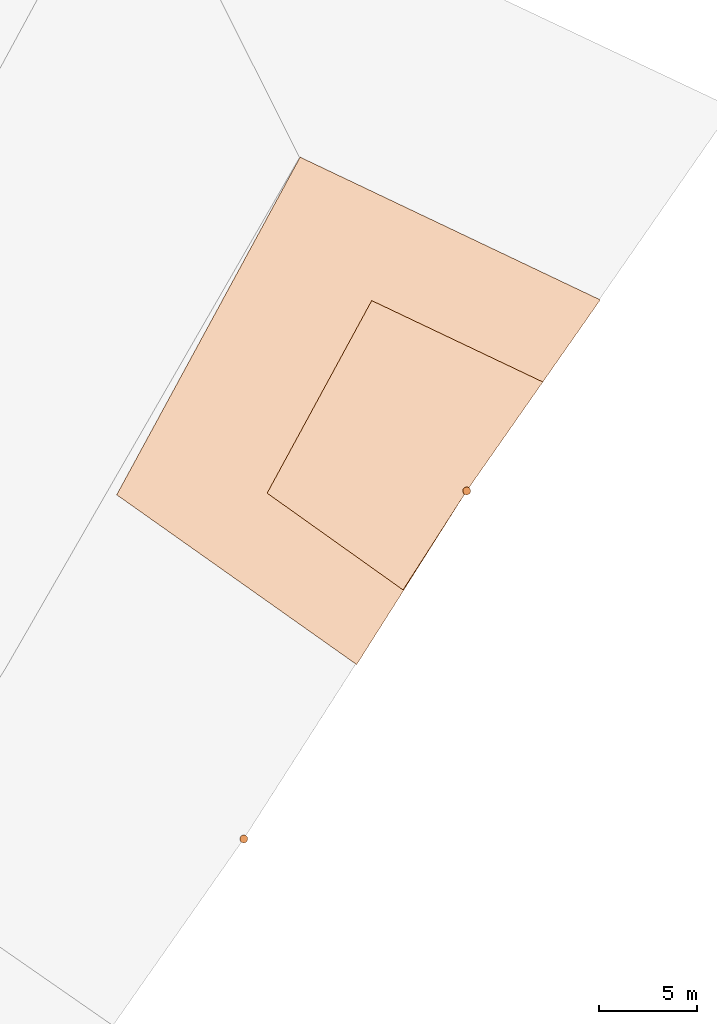
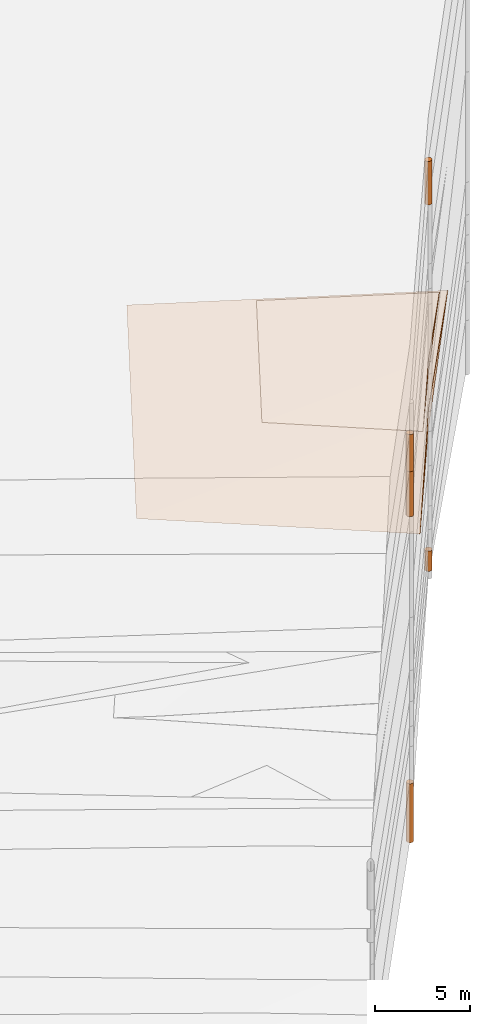
# One storey, part 14 of 24: 7 geographic elements.
"""IFC4 building model written with IfcOpenShell, lengths in metres."""

from ifc_helpers import new_model, entity, si_unit, converted_unit, frame, origin_with_axes, origin_2d_with_axis, place, context, subcontext, project, spatial, polygons, element, save


model = new_model("IFC4")

# Units and contexts
model_context = context("Model", 3, precision=1e-05, world=origin_with_axes())
plan_context = context("Plan", 2, precision=1e-05, world=origin_2d_with_axis())
body_context = subcontext(model_context, "Body", "Model", "MODEL_VIEW")
ifc_project = project(units=[converted_unit("PLANEANGLEUNIT", "degree", entity("IfcReal", 0.0174532925199433), si_unit("PLANEANGLEUNIT", "RADIAN"), dimensions=[0, 0, 0, 0, 0, 0, 0]), si_unit("AREAUNIT", "SQUARE_METRE"), si_unit("VOLUMEUNIT", "CUBIC_METRE"), si_unit("LENGTHUNIT", "METRE")], contexts=[model_context, plan_context])

# Site, building, storey
site_placement = place(None, origin_with_axes())
site = spatial("IfcSite", under=ifc_project, at=site_placement)
building_placement = place(site_placement, origin_with_axes())
building = spatial("IfcBuilding", under=site, at=building_placement, Name="Building")
storey_placement = place(building_placement, origin_with_axes())
storey = spatial("IfcBuildingStorey", under=building, at=storey_placement, Name="Storey")

# Geographic elements
geographic_element_1_placement = place(storey_placement, frame((36.5, 56.7999992370605, 3.20000004768372), z_axis=(0.0, 0.0, 1.0), x_axis=(1.0, 0.0, 0.0)))
element("IfcGeographicElement", 1, at=geographic_element_1_placement, inside=storey, PredefinedType="NOTDEFINED", context=body_context, shape_type="Tessellation", body=[
    polygons([(-3.255779504776, -5.06328010559082, 0.379999846220016), (-1.0875494353968e-06, -9.51605784393905e-07, 1.19209282445354e-07), (0.0, 0.0, 0.799999892711639), (-4.8580117225647, 9.73313045501709, 0.399999856948853), (-10.2063846588135, -0.11403826624155, 0.399999856948853), (3.89439296722412, 5.57074785232544, 0.399999856948853)], [[[3, 1, 2]], [[5, 3, 4]], [[6, 3, 2]], [[4, 3, 6]], [[2, 4, 6]], [[2, 5, 4]], [[5, 1, 3]], [[2, 1, 5]]]),
])
geographic_element_2_placement = place(storey_placement, frame((21.7962417602539, 59.2355880737305, -1.85574865341187), z_axis=(0.0, 0.0, 1.0), x_axis=(1.0, 0.0, 0.0)))
element("IfcGeographicElement", 2, at=geographic_element_2_placement, inside=storey, PredefinedType="NOTDEFINED", context=body_context, shape_type="Tessellation", body=[
    polygons([(9.07574272155762, -11.3183498382568, 1.98574864864349), (14.7037572860718, -2.4355902671814, 1.35574865341187), (14.7037582397461, -2.43558859825134, 2.65574884414673), (6.18375730514526, 14.6344137191772, 2.0057487487793), (-3.1962411403656, -2.6355893611908, 2.0057487487793), (21.5337581634521, 7.33440828323364, 2.0057487487793)], [[[3, 1, 2]], [[5, 3, 4]], [[4, 3, 6]], [[2, 4, 6]], [[6, 3, 2]], [[2, 5, 4]], [[5, 1, 3]], [[2, 1, 5]]]),
])
geographic_element_3_placement = place(storey_placement, frame((36.5, 56.7999992370605, 15.5), z_axis=(0.0, 0.0, 1.0), x_axis=(1.0, 0.0, 0.0)))
element("IfcGeographicElement", 3, at=geographic_element_3_placement, inside=storey, PredefinedType="NOTDEFINED", context=body_context, shape_type="Tessellation", body=[
    polygons([(0.0, 0.0, -1.39999985694885), (0.0390180610120296, 0.196157038211823, -1.39999985694885), (0.0, 0.199999988079071, -1.39999985694885), (0.0, 0.0, 1.39999985694885), (0.0, 0.199999988079071, 1.39999985694885), (0.0390180610120296, 0.196157038211823, 1.39999985694885), (0.0765366926789284, 0.18477588891983, -1.39999985694885), (0.0765366926789284, 0.18477588891983, 1.39999985694885), (0.111114047467709, 0.166293919086456, -1.39999985694885), (0.111114047467709, 0.166293919086456, 1.39999985694885), (0.141421362757683, 0.141421362757683, -1.39999985694885), (0.141421362757683, 0.141421362757683, 1.39999985694885), (0.166293919086456, 0.111114047467709, -1.39999985694885), (0.166293919086456, 0.111114047467709, 1.39999985694885), (0.18477588891983, 0.0765366926789284, -1.39999985694885), (0.18477588891983, 0.0765366926789284, 1.39999985694885), (0.196157038211823, 0.0390180610120296, -1.39999985694885), (0.196157038211823, 0.0390180610120296, 1.39999985694885), (0.199999988079071, 0.0, -1.39999985694885), (0.199999988079071, 0.0, 1.39999985694885), (0.196157038211823, -0.0390180610120296, -1.39999985694885), (0.196157038211823, -0.0390180610120296, 1.39999985694885), (0.18477588891983, -0.0765366926789284, -1.39999985694885), (0.18477588891983, -0.0765366926789284, 1.39999985694885), (0.166293919086456, -0.111114047467709, -1.39999985694885), (0.166293919086456, -0.111114047467709, 1.39999985694885), (0.141421362757683, -0.141421362757683, -1.39999985694885), (0.141421362757683, -0.141421362757683, 1.39999985694885), (0.111114047467709, -0.166293919086456, -1.39999985694885), (0.111114047467709, -0.166293919086456, 1.39999985694885), (0.0765366926789284, -0.18477588891983, -1.39999985694885), (0.0765366926789284, -0.18477588891983, 1.39999985694885), (0.0390180610120296, -0.196157038211823, -1.39999985694885), (0.0390180610120296, -0.196157038211823, 1.39999985694885), (0.0, -0.199999988079071, -1.39999985694885), (0.0, -0.199999988079071, 1.39999985694885), (-0.0390180610120296, -0.196157038211823, -1.39999985694885), (-0.0390180610120296, -0.196157038211823, 1.39999985694885), (-0.0765366926789284, -0.18477588891983, -1.39999985694885), (-0.0765366926789284, -0.18477588891983, 1.39999985694885), (-0.111114047467709, -0.166293919086456, -1.39999985694885), (-0.111114047467709, -0.166293919086456, 1.39999985694885), (-0.141421362757683, -0.141421362757683, -1.39999985694885), (-0.141421362757683, -0.141421362757683, 1.39999985694885), (-0.166293919086456, -0.111114047467709, -1.39999985694885), (-0.166293919086456, -0.111114047467709, 1.39999985694885), (-0.18477588891983, -0.0765366926789284, -1.39999985694885), (-0.18477588891983, -0.0765366926789284, 1.39999985694885), (-0.196157038211823, -0.0390180610120296, -1.39999985694885), (-0.196157038211823, -0.0390180610120296, 1.39999985694885), (-0.199999988079071, 0.0, -1.39999985694885), (-0.199999988079071, 0.0, 1.39999985694885), (-0.196157038211823, 0.0390180610120296, -1.39999985694885), (-0.196157038211823, 0.0390180610120296, 1.39999985694885), (-0.18477588891983, 0.0765366926789284, -1.39999985694885), (-0.18477588891983, 0.0765366926789284, 1.39999985694885), (-0.166293919086456, 0.111114047467709, -1.39999985694885), (-0.166293919086456, 0.111114047467709, 1.39999985694885), (-0.141421362757683, 0.141421362757683, -1.39999985694885), (-0.141421362757683, 0.141421362757683, 1.39999985694885), (-0.111114047467709, 0.166293919086456, -1.39999985694885), (-0.111114047467709, 0.166293919086456, 1.39999985694885), (-0.0765366926789284, 0.18477588891983, -1.39999985694885), (-0.0765366926789284, 0.18477588891983, 1.39999985694885), (-0.0390180610120296, 0.196157038211823, -1.39999985694885), (-0.0390180610120296, 0.196157038211823, 1.39999985694885)], [[[3, 2, 1]], [[6, 5, 4]], [[28, 30, 29, 27]], [[2, 7, 1]], [[8, 6, 4]], [[64, 66, 65, 63]], [[7, 9, 1]], [[10, 8, 4]], [[9, 11, 1]], [[12, 10, 4]], [[6, 8, 7, 2]], [[1, 11, 13]], [[12, 4, 14]], [[66, 5, 3, 65]], [[1, 13, 15]], [[14, 4, 16]], [[12, 14, 13, 11]], [[1, 15, 17]], [[16, 4, 18]], [[14, 16, 15, 13]], [[1, 17, 19]], [[4, 20, 18]], [[16, 18, 17, 15]], [[1, 19, 21]], [[4, 22, 20]], [[18, 20, 19, 17]], [[1, 21, 23]], [[22, 4, 24]], [[20, 22, 21, 19]], [[1, 23, 25]], [[24, 4, 26]], [[22, 24, 23, 21]], [[1, 25, 27]], [[4, 28, 26]], [[24, 26, 25, 23]], [[1, 27, 29]], [[28, 4, 30]], [[26, 28, 27, 25]], [[1, 29, 31]], [[4, 32, 30]], [[5, 6, 2, 3]], [[1, 31, 33]], [[4, 34, 32]], [[30, 32, 31, 29]], [[1, 33, 35]], [[4, 36, 34]], [[8, 10, 9, 7]], [[1, 35, 37]], [[4, 38, 36]], [[32, 34, 33, 31]], [[1, 37, 39]], [[4, 40, 38]], [[36, 38, 37, 35]], [[1, 39, 41]], [[4, 42, 40]], [[38, 40, 39, 37]], [[43, 1, 41]], [[4, 44, 42]], [[40, 42, 41, 39]], [[43, 45, 1]], [[4, 46, 44]], [[42, 44, 43, 41]], [[47, 1, 45]], [[4, 48, 46]], [[44, 46, 45, 43]], [[49, 1, 47]], [[4, 50, 48]], [[46, 48, 47, 45]], [[49, 51, 1]], [[52, 50, 4]], [[48, 50, 49, 47]], [[51, 53, 1]], [[54, 52, 4]], [[50, 52, 51, 49]], [[55, 1, 53]], [[4, 56, 54]], [[52, 54, 53, 51]], [[57, 1, 55]], [[4, 58, 56]], [[54, 56, 55, 53]], [[59, 1, 57]], [[60, 58, 4]], [[56, 58, 57, 55]], [[59, 61, 1]], [[62, 60, 4]], [[58, 60, 59, 57]], [[61, 63, 1]], [[64, 62, 4]], [[60, 62, 61, 59]], [[63, 65, 1]], [[66, 64, 4]], [[62, 64, 63, 61]], [[65, 3, 1]], [[5, 66, 4]], [[34, 36, 35, 33]], [[10, 12, 11, 9]]]),
])
geographic_element_4_placement = place(storey_placement, frame((36.5, 56.7999992370605, -8.85000038146973), z_axis=(0.0, 0.0, 1.0), x_axis=(1.0, 0.0, 0.0)))
element("IfcGeographicElement", 4, at=geographic_element_4_placement, inside=storey, PredefinedType="NOTDEFINED", context=body_context, shape_type="Tessellation", body=[
    polygons([(0.0, 0.0, -0.649999916553497), (0.0390180610120296, 0.196157038211823, -0.649999916553497), (0.0, 0.199999988079071, -0.649999916553497), (0.0, 0.0, 0.649999916553497), (0.0, 0.199999988079071, 0.649999916553497), (0.0390180610120296, 0.196157038211823, 0.649999916553497), (0.0765366926789284, 0.18477588891983, -0.649999916553497), (0.0765366926789284, 0.18477588891983, 0.649999916553497), (0.111114047467709, 0.166293919086456, -0.649999916553497), (0.111114047467709, 0.166293919086456, 0.649999916553497), (0.141421362757683, 0.141421362757683, -0.649999916553497), (0.141421362757683, 0.141421362757683, 0.649999916553497), (0.166293919086456, 0.111114047467709, -0.649999916553497), (0.166293919086456, 0.111114047467709, 0.649999916553497), (0.18477588891983, 0.0765366926789284, -0.649999916553497), (0.18477588891983, 0.0765366926789284, 0.649999916553497), (0.196157038211823, 0.0390180610120296, -0.649999916553497), (0.196157038211823, 0.0390180610120296, 0.649999916553497), (0.199999988079071, 0.0, -0.649999916553497), (0.199999988079071, 0.0, 0.649999916553497), (0.196157038211823, -0.0390180610120296, -0.649999916553497), (0.196157038211823, -0.0390180610120296, 0.649999916553497), (0.18477588891983, -0.0765366926789284, -0.649999916553497), (0.18477588891983, -0.0765366926789284, 0.649999916553497), (0.166293919086456, -0.111114047467709, -0.649999916553497), (0.166293919086456, -0.111114047467709, 0.649999916553497), (0.141421362757683, -0.141421362757683, -0.649999916553497), (0.141421362757683, -0.141421362757683, 0.649999916553497), (0.111114047467709, -0.166293919086456, -0.649999916553497), (0.111114047467709, -0.166293919086456, 0.649999916553497), (0.0765366926789284, -0.18477588891983, -0.649999916553497), (0.0765366926789284, -0.18477588891983, 0.649999916553497), (0.0390180610120296, -0.196157038211823, -0.649999916553497), (0.0390180610120296, -0.196157038211823, 0.649999916553497), (0.0, -0.199999988079071, -0.649999916553497), (0.0, -0.199999988079071, 0.649999916553497), (-0.0390180610120296, -0.196157038211823, -0.649999916553497), (-0.0390180610120296, -0.196157038211823, 0.649999916553497), (-0.0765366926789284, -0.18477588891983, -0.649999916553497), (-0.0765366926789284, -0.18477588891983, 0.649999916553497), (-0.111114047467709, -0.166293919086456, -0.649999916553497), (-0.111114047467709, -0.166293919086456, 0.649999916553497), (-0.141421362757683, -0.141421362757683, -0.649999916553497), (-0.141421362757683, -0.141421362757683, 0.649999916553497), (-0.166293919086456, -0.111114047467709, -0.649999916553497), (-0.166293919086456, -0.111114047467709, 0.649999916553497), (-0.18477588891983, -0.0765366926789284, -0.649999916553497), (-0.18477588891983, -0.0765366926789284, 0.649999916553497), (-0.196157038211823, -0.0390180610120296, -0.649999916553497), (-0.196157038211823, -0.0390180610120296, 0.649999916553497), (-0.199999988079071, 0.0, -0.649999916553497), (-0.199999988079071, 0.0, 0.649999916553497), (-0.196157038211823, 0.0390180610120296, -0.649999916553497), (-0.196157038211823, 0.0390180610120296, 0.649999916553497), (-0.18477588891983, 0.0765366926789284, -0.649999916553497), (-0.18477588891983, 0.0765366926789284, 0.649999916553497), (-0.166293919086456, 0.111114047467709, -0.649999916553497), (-0.166293919086456, 0.111114047467709, 0.649999916553497), (-0.141421362757683, 0.141421362757683, -0.649999916553497), (-0.141421362757683, 0.141421362757683, 0.649999916553497), (-0.111114047467709, 0.166293919086456, -0.649999916553497), (-0.111114047467709, 0.166293919086456, 0.649999916553497), (-0.0765366926789284, 0.18477588891983, -0.649999916553497), (-0.0765366926789284, 0.18477588891983, 0.649999916553497), (-0.0390180610120296, 0.196157038211823, -0.649999916553497), (-0.0390180610120296, 0.196157038211823, 0.649999916553497)], [[[3, 2, 1]], [[6, 5, 4]], [[32, 34, 33, 31]], [[2, 7, 1]], [[8, 6, 4]], [[64, 66, 65, 63]], [[7, 9, 1]], [[10, 8, 4]], [[9, 11, 1]], [[12, 10, 4]], [[40, 42, 41, 39]], [[1, 11, 13]], [[12, 4, 14]], [[10, 12, 11, 9]], [[1, 13, 15]], [[4, 16, 14]], [[12, 14, 13, 11]], [[1, 15, 17]], [[4, 18, 16]], [[18, 20, 19, 17]], [[1, 17, 19]], [[4, 20, 18]], [[20, 22, 21, 19]], [[1, 19, 21]], [[4, 22, 20]], [[22, 24, 23, 21]], [[1, 21, 23]], [[22, 4, 24]], [[54, 56, 55, 53]], [[1, 23, 25]], [[24, 4, 26]], [[56, 58, 57, 55]], [[1, 25, 27]], [[4, 28, 26]], [[24, 26, 25, 23]], [[1, 27, 29]], [[28, 4, 30]], [[26, 28, 27, 25]], [[1, 29, 31]], [[4, 32, 30]], [[46, 48, 47, 45]], [[1, 31, 33]], [[4, 34, 32]], [[36, 38, 37, 35]], [[1, 33, 35]], [[4, 36, 34]], [[42, 44, 43, 41]], [[1, 35, 37]], [[4, 38, 36]], [[38, 40, 39, 37]], [[1, 37, 39]], [[4, 40, 38]], [[34, 36, 35, 33]], [[1, 39, 41]], [[4, 42, 40]], [[8, 10, 9, 7]], [[43, 1, 41]], [[4, 44, 42]], [[44, 46, 45, 43]], [[43, 45, 1]], [[4, 46, 44]], [[30, 32, 31, 29]], [[47, 1, 45]], [[48, 46, 4]], [[28, 30, 29, 27]], [[49, 1, 47]], [[50, 48, 4]], [[5, 6, 2, 3]], [[49, 51, 1]], [[52, 50, 4]], [[48, 50, 49, 47]], [[51, 53, 1]], [[54, 52, 4]], [[50, 52, 51, 49]], [[53, 55, 1]], [[4, 56, 54]], [[52, 54, 53, 51]], [[55, 57, 1]], [[4, 58, 56]], [[58, 60, 59, 57]], [[59, 1, 57]], [[60, 58, 4]], [[60, 62, 61, 59]], [[59, 61, 1]], [[62, 60, 4]], [[62, 64, 63, 61]], [[61, 63, 1]], [[64, 62, 4]], [[14, 16, 15, 13]], [[63, 65, 1]], [[66, 64, 4]], [[16, 18, 17, 15]], [[65, 3, 1]], [[5, 66, 4]], [[6, 8, 7, 2]], [[66, 5, 3, 65]]]),
])
geographic_element_5_placement = place(storey_placement, frame((25.1000003814697, 39.0, 10.2545013427734), z_axis=(0.0, 0.0, 1.0), x_axis=(1.0, 0.0, 0.0)))
element("IfcGeographicElement", 5, at=geographic_element_5_placement, inside=storey, PredefinedType="NOTDEFINED", context=body_context, shape_type="Tessellation", body=[
    polygons([(0.0, 0.0, -1.4485000371933), (0.0390180610120296, 0.196157038211823, -1.4485000371933), (0.0, 0.199999988079071, -1.4485000371933), (0.0, 0.0, 1.4485000371933), (0.0, 0.199999988079071, 1.4485000371933), (0.0390180610120296, 0.196157038211823, 1.4485000371933), (0.0765366926789284, 0.18477588891983, -1.4485000371933), (0.0765366926789284, 0.18477588891983, 1.4485000371933), (0.111114047467709, 0.166293919086456, -1.4485000371933), (0.111114047467709, 0.166293919086456, 1.4485000371933), (0.141421362757683, 0.141421362757683, -1.4485000371933), (0.141421362757683, 0.141421362757683, 1.4485000371933), (0.166293919086456, 0.111114047467709, -1.4485000371933), (0.166293919086456, 0.111114047467709, 1.4485000371933), (0.18477588891983, 0.0765366926789284, -1.4485000371933), (0.18477588891983, 0.0765366926789284, 1.4485000371933), (0.196157038211823, 0.0390180610120296, -1.4485000371933), (0.196157038211823, 0.0390180610120296, 1.4485000371933), (0.199999988079071, 0.0, -1.4485000371933), (0.199999988079071, 0.0, 1.4485000371933), (0.196157038211823, -0.0390180610120296, -1.4485000371933), (0.196157038211823, -0.0390180610120296, 1.4485000371933), (0.18477588891983, -0.0765366926789284, -1.4485000371933), (0.18477588891983, -0.0765366926789284, 1.4485000371933), (0.166293919086456, -0.111114047467709, -1.4485000371933), (0.166293919086456, -0.111114047467709, 1.4485000371933), (0.141421362757683, -0.141421362757683, -1.4485000371933), (0.141421362757683, -0.141421362757683, 1.4485000371933), (0.111114047467709, -0.166293919086456, -1.4485000371933), (0.111114047467709, -0.166293919086456, 1.4485000371933), (0.0765366926789284, -0.18477588891983, -1.4485000371933), (0.0765366926789284, -0.18477588891983, 1.4485000371933), (0.0390180610120296, -0.196157038211823, -1.4485000371933), (0.0390180610120296, -0.196157038211823, 1.4485000371933), (0.0, -0.199999988079071, -1.4485000371933), (0.0, -0.199999988079071, 1.4485000371933), (-0.0390180610120296, -0.196157038211823, -1.4485000371933), (-0.0390180610120296, -0.196157038211823, 1.4485000371933), (-0.0765366926789284, -0.18477588891983, -1.4485000371933), (-0.0765366926789284, -0.18477588891983, 1.4485000371933), (-0.111114047467709, -0.166293919086456, -1.4485000371933), (-0.111114047467709, -0.166293919086456, 1.4485000371933), (-0.141421362757683, -0.141421362757683, -1.4485000371933), (-0.141421362757683, -0.141421362757683, 1.4485000371933), (-0.166293919086456, -0.111114047467709, -1.4485000371933), (-0.166293919086456, -0.111114047467709, 1.4485000371933), (-0.18477588891983, -0.0765366926789284, -1.4485000371933), (-0.18477588891983, -0.0765366926789284, 1.4485000371933), (-0.196157038211823, -0.0390180610120296, -1.4485000371933), (-0.196157038211823, -0.0390180610120296, 1.4485000371933), (-0.199999988079071, 0.0, -1.4485000371933), (-0.199999988079071, 0.0, 1.4485000371933), (-0.196157038211823, 0.0390180610120296, -1.4485000371933), (-0.196157038211823, 0.0390180610120296, 1.4485000371933), (-0.18477588891983, 0.0765366926789284, -1.4485000371933), (-0.18477588891983, 0.0765366926789284, 1.4485000371933), (-0.166293919086456, 0.111114047467709, -1.4485000371933), (-0.166293919086456, 0.111114047467709, 1.4485000371933), (-0.141421362757683, 0.141421362757683, -1.4485000371933), (-0.141421362757683, 0.141421362757683, 1.4485000371933), (-0.111114047467709, 0.166293919086456, -1.4485000371933), (-0.111114047467709, 0.166293919086456, 1.4485000371933), (-0.0765366926789284, 0.18477588891983, -1.4485000371933), (-0.0765366926789284, 0.18477588891983, 1.4485000371933), (-0.0390180610120296, 0.196157038211823, -1.4485000371933), (-0.0390180610120296, 0.196157038211823, 1.4485000371933)], [[[3, 2, 1]], [[6, 5, 4]], [[32, 34, 33, 31]], [[2, 7, 1]], [[8, 6, 4]], [[64, 66, 65, 63]], [[7, 9, 1]], [[10, 8, 4]], [[9, 11, 1]], [[12, 10, 4]], [[40, 42, 41, 39]], [[1, 11, 13]], [[12, 4, 14]], [[10, 12, 11, 9]], [[1, 13, 15]], [[4, 16, 14]], [[12, 14, 13, 11]], [[1, 15, 17]], [[4, 18, 16]], [[18, 20, 19, 17]], [[1, 17, 19]], [[4, 20, 18]], [[20, 22, 21, 19]], [[1, 19, 21]], [[4, 22, 20]], [[22, 24, 23, 21]], [[1, 21, 23]], [[4, 24, 22]], [[54, 56, 55, 53]], [[1, 23, 25]], [[4, 26, 24]], [[56, 58, 57, 55]], [[27, 1, 25]], [[4, 28, 26]], [[24, 26, 25, 23]], [[1, 27, 29]], [[28, 4, 30]], [[26, 28, 27, 25]], [[1, 29, 31]], [[4, 32, 30]], [[46, 48, 47, 45]], [[1, 31, 33]], [[4, 34, 32]], [[36, 38, 37, 35]], [[1, 33, 35]], [[4, 36, 34]], [[42, 44, 43, 41]], [[1, 35, 37]], [[4, 38, 36]], [[38, 40, 39, 37]], [[1, 37, 39]], [[4, 40, 38]], [[34, 36, 35, 33]], [[1, 39, 41]], [[4, 42, 40]], [[8, 10, 9, 7]], [[43, 1, 41]], [[4, 44, 42]], [[44, 46, 45, 43]], [[43, 45, 1]], [[46, 44, 4]], [[30, 32, 31, 29]], [[45, 47, 1]], [[48, 46, 4]], [[28, 30, 29, 27]], [[47, 49, 1]], [[50, 48, 4]], [[5, 6, 2, 3]], [[49, 51, 1]], [[52, 50, 4]], [[48, 50, 49, 47]], [[51, 53, 1]], [[54, 52, 4]], [[50, 52, 51, 49]], [[53, 55, 1]], [[56, 54, 4]], [[52, 54, 53, 51]], [[55, 57, 1]], [[58, 56, 4]], [[58, 60, 59, 57]], [[57, 59, 1]], [[60, 58, 4]], [[60, 62, 61, 59]], [[59, 61, 1]], [[62, 60, 4]], [[62, 64, 63, 61]], [[61, 63, 1]], [[64, 62, 4]], [[14, 16, 15, 13]], [[63, 65, 1]], [[66, 64, 4]], [[16, 18, 17, 15]], [[65, 3, 1]], [[5, 66, 4]], [[6, 8, 7, 2]], [[66, 5, 3, 65]]]),
])
geographic_element_6_placement = place(storey_placement, frame((25.1000003814697, 39.0, 12.9015007019043), z_axis=(0.0, 0.0, 1.0), x_axis=(1.0, 0.0, 0.0)))
element("IfcGeographicElement", 6, at=geographic_element_6_placement, inside=storey, PredefinedType="NOTDEFINED", context=body_context, shape_type="Tessellation", body=[
    polygons([(0.0, 0.0, -1.1985000371933), (0.0390180610120296, 0.196157038211823, -1.1985000371933), (0.0, 0.199999988079071, -1.1985000371933), (0.0, 0.0, 1.1985000371933), (0.0, 0.199999988079071, 1.1985000371933), (0.0390180610120296, 0.196157038211823, 1.1985000371933), (0.0765366926789284, 0.18477588891983, -1.1985000371933), (0.0765366926789284, 0.18477588891983, 1.1985000371933), (0.111114047467709, 0.166293919086456, -1.1985000371933), (0.111114047467709, 0.166293919086456, 1.1985000371933), (0.141421362757683, 0.141421362757683, -1.1985000371933), (0.141421362757683, 0.141421362757683, 1.1985000371933), (0.166293919086456, 0.111114047467709, -1.1985000371933), (0.166293919086456, 0.111114047467709, 1.1985000371933), (0.18477588891983, 0.0765366926789284, -1.1985000371933), (0.18477588891983, 0.0765366926789284, 1.1985000371933), (0.196157038211823, 0.0390180610120296, -1.1985000371933), (0.196157038211823, 0.0390180610120296, 1.1985000371933), (0.199999988079071, 0.0, -1.1985000371933), (0.199999988079071, 0.0, 1.1985000371933), (0.196157038211823, -0.0390180610120296, -1.1985000371933), (0.196157038211823, -0.0390180610120296, 1.1985000371933), (0.18477588891983, -0.0765366926789284, -1.1985000371933), (0.18477588891983, -0.0765366926789284, 1.1985000371933), (0.166293919086456, -0.111114047467709, -1.1985000371933), (0.166293919086456, -0.111114047467709, 1.1985000371933), (0.141421362757683, -0.141421362757683, -1.1985000371933), (0.141421362757683, -0.141421362757683, 1.1985000371933), (0.111114047467709, -0.166293919086456, -1.1985000371933), (0.111114047467709, -0.166293919086456, 1.1985000371933), (0.0765366926789284, -0.18477588891983, -1.1985000371933), (0.0765366926789284, -0.18477588891983, 1.1985000371933), (0.0390180610120296, -0.196157038211823, -1.1985000371933), (0.0390180610120296, -0.196157038211823, 1.1985000371933), (0.0, -0.199999988079071, -1.1985000371933), (0.0, -0.199999988079071, 1.1985000371933), (-0.0390180610120296, -0.196157038211823, -1.1985000371933), (-0.0390180610120296, -0.196157038211823, 1.1985000371933), (-0.0765366926789284, -0.18477588891983, -1.1985000371933), (-0.0765366926789284, -0.18477588891983, 1.1985000371933), (-0.111114047467709, -0.166293919086456, -1.1985000371933), (-0.111114047467709, -0.166293919086456, 1.1985000371933), (-0.141421362757683, -0.141421362757683, -1.1985000371933), (-0.141421362757683, -0.141421362757683, 1.1985000371933), (-0.166293919086456, -0.111114047467709, -1.1985000371933), (-0.166293919086456, -0.111114047467709, 1.1985000371933), (-0.18477588891983, -0.0765366926789284, -1.1985000371933), (-0.18477588891983, -0.0765366926789284, 1.1985000371933), (-0.196157038211823, -0.0390180610120296, -1.1985000371933), (-0.196157038211823, -0.0390180610120296, 1.1985000371933), (-0.199999988079071, 0.0, -1.1985000371933), (-0.199999988079071, 0.0, 1.1985000371933), (-0.196157038211823, 0.0390180610120296, -1.1985000371933), (-0.196157038211823, 0.0390180610120296, 1.1985000371933), (-0.18477588891983, 0.0765366926789284, -1.1985000371933), (-0.18477588891983, 0.0765366926789284, 1.1985000371933), (-0.166293919086456, 0.111114047467709, -1.1985000371933), (-0.166293919086456, 0.111114047467709, 1.1985000371933), (-0.141421362757683, 0.141421362757683, -1.1985000371933), (-0.141421362757683, 0.141421362757683, 1.1985000371933), (-0.111114047467709, 0.166293919086456, -1.1985000371933), (-0.111114047467709, 0.166293919086456, 1.1985000371933), (-0.0765366926789284, 0.18477588891983, -1.1985000371933), (-0.0765366926789284, 0.18477588891983, 1.1985000371933), (-0.0390180610120296, 0.196157038211823, -1.1985000371933), (-0.0390180610120296, 0.196157038211823, 1.1985000371933)], [[[3, 2, 1]], [[6, 5, 4]], [[28, 30, 29, 27]], [[2, 7, 1]], [[8, 6, 4]], [[64, 66, 65, 63]], [[7, 9, 1]], [[10, 8, 4]], [[9, 11, 1]], [[12, 10, 4]], [[6, 8, 7, 2]], [[1, 11, 13]], [[12, 4, 14]], [[66, 5, 3, 65]], [[1, 13, 15]], [[4, 16, 14]], [[12, 14, 13, 11]], [[1, 15, 17]], [[16, 4, 18]], [[14, 16, 15, 13]], [[1, 17, 19]], [[4, 20, 18]], [[16, 18, 17, 15]], [[1, 19, 21]], [[4, 22, 20]], [[18, 20, 19, 17]], [[1, 21, 23]], [[22, 4, 24]], [[20, 22, 21, 19]], [[1, 23, 25]], [[24, 4, 26]], [[22, 24, 23, 21]], [[1, 25, 27]], [[4, 28, 26]], [[24, 26, 25, 23]], [[1, 27, 29]], [[28, 4, 30]], [[26, 28, 27, 25]], [[1, 29, 31]], [[4, 32, 30]], [[5, 6, 2, 3]], [[1, 31, 33]], [[4, 34, 32]], [[30, 32, 31, 29]], [[1, 33, 35]], [[4, 36, 34]], [[8, 10, 9, 7]], [[1, 35, 37]], [[4, 38, 36]], [[32, 34, 33, 31]], [[1, 37, 39]], [[4, 40, 38]], [[36, 38, 37, 35]], [[1, 39, 41]], [[4, 42, 40]], [[38, 40, 39, 37]], [[43, 1, 41]], [[4, 44, 42]], [[40, 42, 41, 39]], [[43, 45, 1]], [[4, 46, 44]], [[42, 44, 43, 41]], [[47, 1, 45]], [[48, 46, 4]], [[44, 46, 45, 43]], [[49, 1, 47]], [[4, 50, 48]], [[46, 48, 47, 45]], [[49, 51, 1]], [[52, 50, 4]], [[48, 50, 49, 47]], [[51, 53, 1]], [[54, 52, 4]], [[50, 52, 51, 49]], [[55, 1, 53]], [[4, 56, 54]], [[52, 54, 53, 51]], [[55, 57, 1]], [[4, 58, 56]], [[54, 56, 55, 53]], [[59, 1, 57]], [[60, 58, 4]], [[56, 58, 57, 55]], [[59, 61, 1]], [[62, 60, 4]], [[58, 60, 59, 57]], [[61, 63, 1]], [[64, 62, 4]], [[60, 62, 61, 59]], [[63, 65, 1]], [[66, 64, 4]], [[62, 64, 63, 61]], [[65, 3, 1]], [[5, 66, 4]], [[34, 36, 35, 33]], [[10, 12, 11, 9]]]),
])
geographic_element_7_placement = place(storey_placement, frame((25.1000003814697, 39.0, -10.2939987182617), z_axis=(0.0, 0.0, 1.0), x_axis=(1.0, 0.0, 0.0)))
element("IfcGeographicElement", 7, at=geographic_element_7_placement, inside=storey, PredefinedType="NOTDEFINED", context=body_context, shape_type="Tessellation", body=[
    polygons([(0.0, 0.0, -1.89999985694885), (0.0390180610120296, 0.196157038211823, -1.89999985694885), (0.0, 0.199999988079071, -1.89999985694885), (0.0, 0.0, 1.89999985694885), (0.0, 0.199999988079071, 1.89999985694885), (0.0390180610120296, 0.196157038211823, 1.89999985694885), (0.0765366926789284, 0.18477588891983, -1.89999985694885), (0.0765366926789284, 0.18477588891983, 1.89999985694885), (0.111114047467709, 0.166293919086456, -1.89999985694885), (0.111114047467709, 0.166293919086456, 1.89999985694885), (0.141421362757683, 0.141421362757683, -1.89999985694885), (0.141421362757683, 0.141421362757683, 1.89999985694885), (0.166293919086456, 0.111114047467709, -1.89999985694885), (0.166293919086456, 0.111114047467709, 1.89999985694885), (0.18477588891983, 0.0765366926789284, -1.89999985694885), (0.18477588891983, 0.0765366926789284, 1.89999985694885), (0.196157038211823, 0.0390180610120296, -1.89999985694885), (0.196157038211823, 0.0390180610120296, 1.89999985694885), (0.199999988079071, 0.0, -1.89999985694885), (0.199999988079071, 0.0, 1.89999985694885), (0.196157038211823, -0.0390180610120296, -1.89999985694885), (0.196157038211823, -0.0390180610120296, 1.89999985694885), (0.18477588891983, -0.0765366926789284, -1.89999985694885), (0.18477588891983, -0.0765366926789284, 1.89999985694885), (0.166293919086456, -0.111114047467709, -1.89999985694885), (0.166293919086456, -0.111114047467709, 1.89999985694885), (0.141421362757683, -0.141421362757683, -1.89999985694885), (0.141421362757683, -0.141421362757683, 1.89999985694885), (0.111114047467709, -0.166293919086456, -1.89999985694885), (0.111114047467709, -0.166293919086456, 1.89999985694885), (0.0765366926789284, -0.18477588891983, -1.89999985694885), (0.0765366926789284, -0.18477588891983, 1.89999985694885), (0.0390180610120296, -0.196157038211823, -1.89999985694885), (0.0390180610120296, -0.196157038211823, 1.89999985694885), (0.0, -0.199999988079071, -1.89999985694885), (0.0, -0.199999988079071, 1.89999985694885), (-0.0390180610120296, -0.196157038211823, -1.89999985694885), (-0.0390180610120296, -0.196157038211823, 1.89999985694885), (-0.0765366926789284, -0.18477588891983, -1.89999985694885), (-0.0765366926789284, -0.18477588891983, 1.89999985694885), (-0.111114047467709, -0.166293919086456, -1.89999985694885), (-0.111114047467709, -0.166293919086456, 1.89999985694885), (-0.141421362757683, -0.141421362757683, -1.89999985694885), (-0.141421362757683, -0.141421362757683, 1.89999985694885), (-0.166293919086456, -0.111114047467709, -1.89999985694885), (-0.166293919086456, -0.111114047467709, 1.89999985694885), (-0.18477588891983, -0.0765366926789284, -1.89999985694885), (-0.18477588891983, -0.0765366926789284, 1.89999985694885), (-0.196157038211823, -0.0390180610120296, -1.89999985694885), (-0.196157038211823, -0.0390180610120296, 1.89999985694885), (-0.199999988079071, 0.0, -1.89999985694885), (-0.199999988079071, 0.0, 1.89999985694885), (-0.196157038211823, 0.0390180610120296, -1.89999985694885), (-0.196157038211823, 0.0390180610120296, 1.89999985694885), (-0.18477588891983, 0.0765366926789284, -1.89999985694885), (-0.18477588891983, 0.0765366926789284, 1.89999985694885), (-0.166293919086456, 0.111114047467709, -1.89999985694885), (-0.166293919086456, 0.111114047467709, 1.89999985694885), (-0.141421362757683, 0.141421362757683, -1.89999985694885), (-0.141421362757683, 0.141421362757683, 1.89999985694885), (-0.111114047467709, 0.166293919086456, -1.89999985694885), (-0.111114047467709, 0.166293919086456, 1.89999985694885), (-0.0765366926789284, 0.18477588891983, -1.89999985694885), (-0.0765366926789284, 0.18477588891983, 1.89999985694885), (-0.0390180610120296, 0.196157038211823, -1.89999985694885), (-0.0390180610120296, 0.196157038211823, 1.89999985694885)], [[[3, 2, 1]], [[6, 5, 4]], [[34, 36, 35, 33]], [[2, 7, 1]], [[8, 6, 4]], [[36, 38, 37, 35]], [[7, 9, 1]], [[10, 8, 4]], [[56, 58, 57, 55]], [[9, 11, 1]], [[12, 10, 4]], [[58, 60, 59, 57]], [[11, 13, 1]], [[12, 4, 14]], [[8, 10, 9, 7]], [[1, 13, 15]], [[4, 16, 14]], [[10, 12, 11, 9]], [[1, 15, 17]], [[16, 4, 18]], [[18, 20, 19, 17]], [[1, 17, 19]], [[4, 20, 18]], [[20, 22, 21, 19]], [[1, 19, 21]], [[4, 22, 20]], [[22, 24, 23, 21]], [[1, 21, 23]], [[4, 24, 22]], [[38, 40, 39, 37]], [[1, 23, 25]], [[4, 26, 24]], [[40, 42, 41, 39]], [[27, 1, 25]], [[26, 4, 28]], [[24, 26, 25, 23]], [[1, 27, 29]], [[28, 4, 30]], [[62, 64, 63, 61]], [[1, 29, 31]], [[4, 32, 30]], [[28, 30, 29, 27]], [[1, 31, 33]], [[4, 34, 32]], [[5, 6, 2, 3]], [[1, 33, 35]], [[4, 36, 34]], [[30, 32, 31, 29]], [[1, 35, 37]], [[4, 38, 36]], [[32, 34, 33, 31]], [[1, 37, 39]], [[4, 40, 38]], [[6, 8, 7, 2]], [[1, 39, 41]], [[4, 42, 40]], [[42, 44, 43, 41]], [[43, 1, 41]], [[4, 44, 42]], [[44, 46, 45, 43]], [[45, 1, 43]], [[46, 44, 4]], [[46, 48, 47, 45]], [[45, 47, 1]], [[48, 46, 4]], [[60, 62, 61, 59]], [[47, 49, 1]], [[4, 50, 48]], [[16, 18, 17, 15]], [[49, 51, 1]], [[52, 50, 4]], [[48, 50, 49, 47]], [[51, 53, 1]], [[54, 52, 4]], [[66, 5, 3, 65]], [[55, 1, 53]], [[56, 54, 4]], [[52, 54, 53, 51]], [[55, 57, 1]], [[58, 56, 4]], [[57, 59, 1]], [[60, 58, 4]], [[12, 14, 13, 11]], [[59, 61, 1]], [[62, 60, 4]], [[14, 16, 15, 13]], [[61, 63, 1]], [[64, 62, 4]], [[26, 28, 27, 25]], [[63, 65, 1]], [[66, 64, 4]], [[54, 56, 55, 53]], [[65, 3, 1]], [[5, 66, 4]], [[50, 52, 51, 49]], [[64, 66, 65, 63]]]),
])

save(model, "model.ifc")
